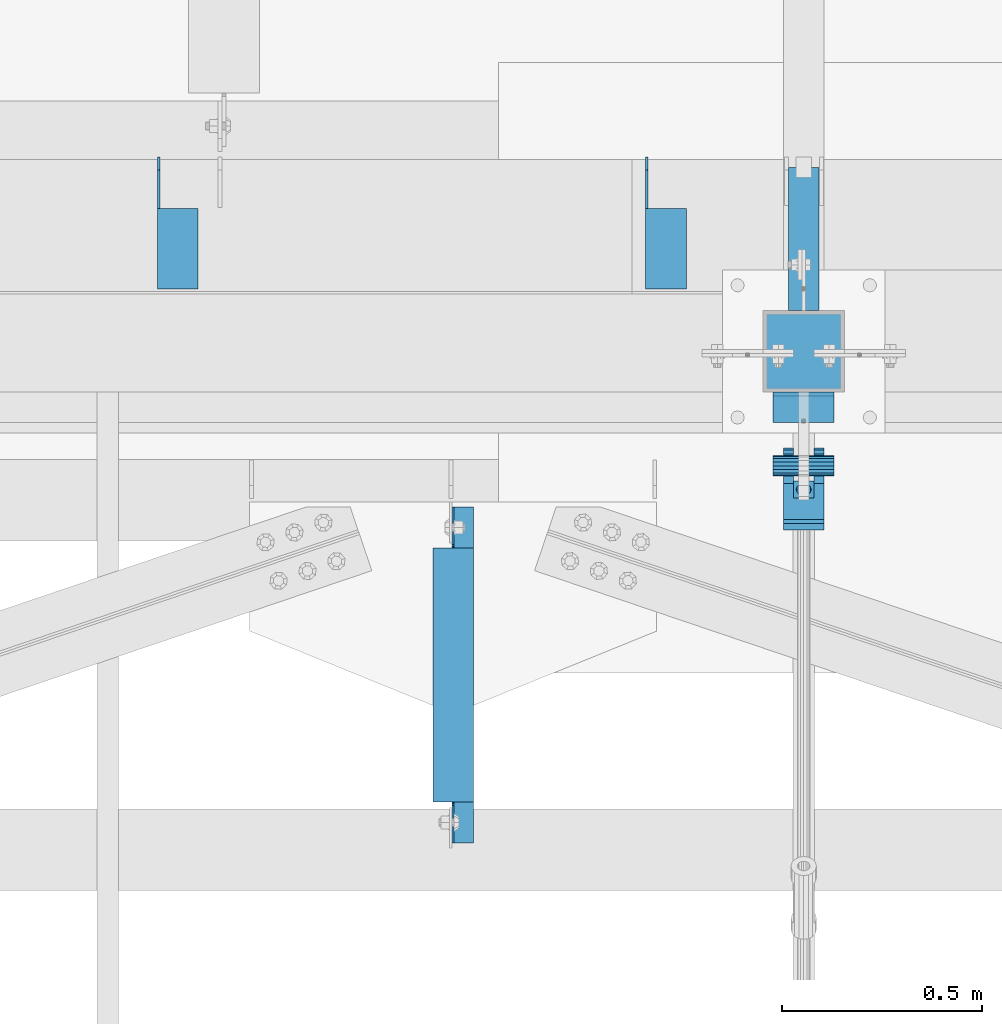
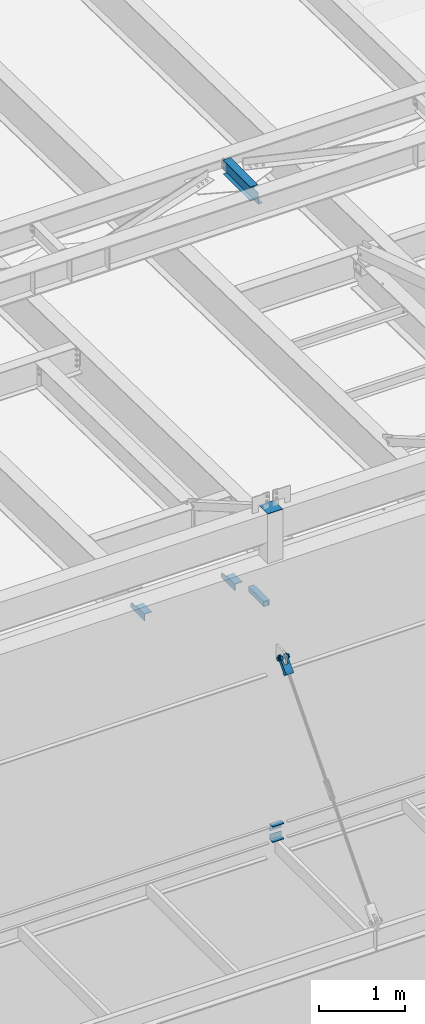
# One storey, part 1206 of 1763: 8 beams, 1 member, 6 elements without a shape of their own.
"""IFC2X3 building model written with IfcOpenShell, lengths in millimetres."""

from ifc_helpers import new_model, si_unit, frame, origin_with_axes, place, context, subcontext, project, spatial, faceted_brep, material, type_object, element, aggregate, save


model = new_model("IFC2X3")

# Units and contexts
model_context = context("Model", 3, precision=1e-05, world=origin_with_axes())
body_context = subcontext(model_context, "Body", "Model", "MODEL_VIEW")
ifc_project = project(units=[si_unit("LENGTHUNIT", "METRE", prefix="MILLI"), si_unit("AREAUNIT", "SQUARE_METRE"), si_unit("VOLUMEUNIT", "CUBIC_METRE"), si_unit("MASSUNIT", "GRAM", prefix="KILO"), si_unit("TIMEUNIT", "SECOND"), si_unit("PLANEANGLEUNIT", "RADIAN"), si_unit("SOLIDANGLEUNIT", "STERADIAN"), si_unit("THERMODYNAMICTEMPERATUREUNIT", "DEGREE_CELSIUS"), si_unit("LUMINOUSINTENSITYUNIT", "LUMEN")], contexts=[model_context])

# Site, building, storey
site_placement = place(None, origin_with_axes())
site = spatial("IfcSite", under=ifc_project, at=site_placement, CompositionType="ELEMENT")
building_placement = place(site_placement, origin_with_axes())
building = spatial("IfcBuilding", under=site, at=building_placement, Name="Undefined", CompositionType="ELEMENT")
storey_placement = place(building_placement, origin_with_axes())
storey = spatial("IfcBuildingStorey", under=building, at=storey_placement, Name="Undefined", CompositionType="ELEMENT", Elevation=0.0)

# Assembly, beams
assembly_1_placement = place(storey_placement, origin_with_axes())
assembly_1 = element("IfcElementAssembly", 1, at=assembly_1_placement, inside=storey, Name="BEAM", AssemblyPlace="NOTDEFINED", PredefinedType="RIGID_FRAME")
ifc_material_1 = material(Name="STEEL/A36")
beam_type_1 = type_object("IfcBeamType", Name="L4X4X1/4", PredefinedType="NOTDEFINED")
beam_1_placement = place(assembly_1_placement, frame((-52362.4055562795, -13723.1435701431, 12153.9), z_axis=(0.0, 0.0, -1.0), x_axis=(0.0, -1.0, 0.0)))
beam_1 = element("IfcBeam", 2, at=beam_1_placement, type_object=beam_type_1, material=ifc_material_1, Name="BRACE", ObjectType="L4X4X1/4", context=body_context, shape_type="Brep", body=[
    faceted_brep([(127.793748474227, 44.4499999999971, -31.7500007627295), (127.793748474227, 50.8000000000029, -31.7500007627295), (127.793748474225, 50.8000000000029, -50.7999999999993), (127.793748474225, -50.8000000000029, -50.7999999999993), (127.793748474225, -50.8000000000029, -44.4500000000007), (127.793748474225, 44.4499999999971, -44.4500000000007), (31.7499999999673, 44.4499999999971, -31.7500001906901), (31.7499999999673, 50.8000000000029, -31.7500007627295), (-1.81898940354586e-10, 44.4500000000371, 50.7999999999374), (-1.96450855582952e-10, 50.8000000000393, 50.7999999999374), (0.0, 50.8000000000029, -1.90690116141923e-07), (0.0, 44.4499999999971, -1.90690116141923e-07), (329.406260681253, 44.4499999999971, 50.7999999999993), (329.406260681253, 50.8000000000029, 50.7999999999993), (329.406260681253, 44.4499999999971, -44.4500000000007), (329.406260681253, -50.8000000000029, -44.4500000000007), (329.406260681253, -50.8000000000029, -50.7999999999993), (329.406260681253, 50.8000000000029, -50.7999999999993)], [[[0, 1, 2, 3, 4, 5]], [[1, 0, 6, 7]], [[8, 9, 10, 11]], [[9, 8, 12, 13]], [[12, 14, 15, 16, 17, 13]], [[15, 14, 5, 4]], [[16, 15, 4, 3]], [[17, 16, 3, 2]], [[9, 13, 17, 2, 1, 7, 10]], [[6, 11, 10, 7]], [[0, 5, 14, 12, 8, 11, 6]]]),
])
beam_2_placement = place(assembly_1_placement, frame((-53581.6055562795, -13723.1435701432, 12153.9), z_axis=(0.0, 0.0, -1.0), x_axis=(0.0, -1.0, 0.0)))
beam_2 = element("IfcBeam", 3, at=beam_2_placement, type_object=beam_type_1, material=ifc_material_1, Name="BRACE", ObjectType="L4X4X1/4", context=body_context, shape_type="Brep", body=[
    faceted_brep([(127.793748474227, 44.4499999999971, -31.7500007627295), (127.793748474227, 50.8000000000029, -31.7500007627295), (127.793748474225, 50.8000000000029, -50.7999999999993), (127.793748474225, -50.8000000000029, -50.7999999999993), (127.793748474225, -50.8000000000029, -44.4500000000007), (127.793748474225, 44.4499999999971, -44.4500000000007), (31.7499999999673, 44.4499999999971, -31.7500001906901), (31.7499999999673, 50.8000000000029, -31.7500007627295), (-1.81898940354586e-10, 44.4500000000371, 50.7999999999374), (-1.96450855582952e-10, 50.8000000000393, 50.7999999999374), (0.0, 50.8000000000029, -1.90690116141923e-07), (0.0, 44.4499999999971, -1.90690116141923e-07), (329.406260681253, 44.4499999999971, 50.7999999999993), (329.406260681253, 50.8000000000029, 50.7999999999993), (329.406260681253, 44.4499999999971, -44.4500000000007), (329.406260681253, -50.8000000000029, -44.4500000000007), (329.406260681253, -50.8000000000029, -50.7999999999993), (329.406260681253, 50.8000000000029, -50.7999999999993)], [[[0, 1, 2, 3, 4, 5]], [[1, 0, 6, 7]], [[8, 9, 10, 11]], [[9, 8, 12, 13]], [[12, 14, 15, 16, 17, 13]], [[15, 14, 5, 4]], [[16, 15, 4, 3]], [[17, 16, 3, 2]], [[9, 13, 17, 2, 1, 7, 10]], [[6, 11, 10, 7]], [[0, 5, 14, 12, 8, 11, 6]]]),
])
aggregate(assembly_1, [beam_1, beam_2])

# Assembly, beam
assembly_2_placement = place(storey_placement, origin_with_axes())
assembly_2 = element("IfcElementAssembly", 4, at=assembly_2_placement, inside=storey, Name="BEAM", AssemblyPlace="NOTDEFINED", PredefinedType="RIGID_FRAME")
ifc_material_2 = material()
beam_type_2 = type_object("IfcBeamType", Name="HSS3X3X1/4", PredefinedType="NOTDEFINED")
beam_3_placement = place(assembly_2_placement, frame((-52018.627008321, -14106.5276214906, 11825.2875), z_axis=(0.0, 0.0, 1.0), x_axis=(0.0, 1.0, 0.0)))
beam_3 = element("IfcBeam", 5, at=beam_3_placement, type_object=beam_type_2, material=ifc_material_2, Name="BEAM", ObjectType="HSS3X3X1/4", context=body_context, shape_type="Brep", body=[
    faceted_brep([(0.0, 31.75, -31.75), (0.0, -31.75, -31.75), (357.9840528735, -31.75, -31.75), (357.9840528735, 31.75, -31.75), (0.0, -31.75, 31.75), (357.9840528735, -31.75, 31.75), (0.0, 31.75, 31.75), (357.9840528735, 31.75, 31.75), (0.0, 38.0999999999985, -38.1000000000004), (0.0, 38.0999999999985, 38.1000000000004), (357.9840528735, 38.0999999999985, 38.1000000000004), (357.9840528735, 38.0999999999985, -38.1000000000004), (0.0, -38.0999999999985, 38.1000000000004), (357.9840528735, -38.0999999999985, 38.1000000000004), (0.0, -38.0999999999985, -38.1000000000004), (357.9840528735, -38.0999999999985, -38.1000000000004)], [[[0, 1, 2, 3]], [[1, 4, 5, 2]], [[4, 6, 7, 5]], [[6, 0, 3, 7]], [[8, 9, 10, 11]], [[9, 12, 13, 10]], [[12, 14, 15, 13]], [[14, 8, 11, 15]], [[13, 15, 11, 10], [5, 7, 3, 2]], [[14, 12, 9, 8], [6, 4, 1, 0]]]),
])
aggregate(assembly_2, [beam_3])

assembly_3_placement = place(storey_placement, origin_with_axes())
assembly_3 = element("IfcElementAssembly", 6, at=assembly_3_placement, inside=storey, Name="BEAM", AssemblyPlace="NOTDEFINED", PredefinedType="RIGID_FRAME")
ifc_material_3 = material(Name="STEEL/A992")
beam_type_3 = type_object("IfcBeamType", Name="W8X10", PredefinedType="NOTDEFINED")
beam_4_placement = place(assembly_3_placement, frame((-52893.869131718, -15452.7273151462, 18721.3875), z_axis=(0.0, 0.0, 1.0), x_axis=(0.0, 1.0, 0.0)))
beam_4 = element("IfcBeam", 7, at=beam_4_placement, type_object=beam_type_3, material=ifc_material_3, Name="BEAM", ObjectType="W8X10", context=body_context, shape_type="Brep", body=[
    faceted_brep([(754.06250467346, 2.68138277246908, -95.25), (754.06250467369, 2.68111138139648, -100.012500000001), (754.062463102084, 50.7999999976746, -100.012500000001), (754.062463102084, 50.7999999976746, -95.25), (855.662552488204, 2.68146872577199, -95.25), (855.662521812792, 2.6811990331189, -100.012500000001), (754.062550374047, 50.7999999976746, 95.25), (754.062583734623, 2.38124999781576, 95.25), (119.062582114304, 2.38124999965657, 95.25), (119.062548753725, 50.7999999995227, 95.25), (119.062552665697, -50.8000000003085, 100.012500000001), (119.062548753725, 50.7999999995227, 100.012500000001), (119.062582114406, 2.38124999965657, 74.3525014877341), (119.062585395783, -2.38125000033324, 74.3525014877341), (119.062585395672, -2.38125000033324, 95.25), (119.062552665697, -50.8000000003085, 95.25), (118.095852191816, 2.38124999965657, 69.4924219696877), (118.095855473193, -2.38125000033324, 69.4924219696877), (115.342838291333, 2.38124999966385, 65.3722455015341), (115.342841572712, -2.38125000031869, 65.3722455015341), (111.222661823174, 2.38124999968568, 62.6192316010565), (111.222665104551, -2.38125000031141, 62.6192316010565), (106.362582305122, 2.38124999969295, 61.652501678469), (106.362585586499, -2.38125000029686, 61.652501678469), (17.4625525194206, 2.38124999996217, 61.652501678469), (17.4625530147059, -2.3812500000422, 61.652501678469), (119.062558086149, 50.7999999995154, -95.25), (119.062558086149, 50.7999999995154, -100.012500000001), (119.062651888697, 2.68138385671773, -100.012500000001), (119.062651889202, 2.68111246564513, -95.25), (17.462499936948, 2.68119506251242, -100.012500000001), (17.462552488254, 2.68092308348423, -95.25), (17.4625580501142, -50.8000000000393, -100.012500000001), (17.4625580501142, -50.8000000000393, -95.25), (17.4625530147059, -2.3812500000422, -95.25), (17.4625525194206, 2.38124999996217, -95.25), (855.662558050122, -50.8000000022803, -100.012500000001), (855.662558050122, -50.8000000022803, -95.25), (855.662553014712, -2.3812500022832, -95.25), (855.662553014712, -2.3812500022832, 61.652501678469), (766.762586825173, -2.38125000221044, 61.652501678469), (761.902507307121, -2.38125000219588, 62.6192316010565), (757.78233083896, -2.38125000218133, 65.3722455015341), (755.02931693848, -2.38125000217406, 69.4924219696877), (754.062587015891, -2.38125000216678, 74.3525014877341), (754.062587015991, -2.38125000216678, 95.25), (754.062552665271, -50.8000000020038, 95.25), (754.062552665271, -50.8000000020038, 100.012500000001), (754.062550374047, 50.7999999976746, 100.012500000001), (754.062583734514, 2.38124999781576, 74.3525014877341), (755.029313657102, 2.38124999781576, 69.4924219696877), (757.782327557585, 2.38124999780848, 65.3722455015341), (761.902504025744, 2.38124999779393, 62.6192316010565), (766.762583543798, 2.38124999777938, 61.652501678469), (855.662552519427, 2.38124999772117, 61.652501678469), (855.662552519427, 2.38124999772117, -95.25)], [[[0, 1, 2, 3]], [[4, 5, 1, 0]], [[6, 7, 8, 9]], [[10, 11, 9, 8, 12, 13, 14, 15]], [[13, 12, 16, 17]], [[17, 16, 18, 19]], [[19, 18, 20, 21]], [[21, 20, 22, 23]], [[23, 22, 24, 25]], [[26, 27, 28, 29]], [[29, 28, 30, 31]], [[32, 33, 34, 25, 24, 35, 31, 30]], [[33, 32, 36, 37]], [[34, 33, 37, 38]], [[17, 19, 21, 23, 25, 34, 38, 39, 40, 41, 42, 43, 44, 45, 14, 13]], [[45, 46, 15, 14]], [[46, 47, 10, 15]], [[47, 48, 11, 10]], [[48, 6, 9, 11]], [[47, 46, 45, 44, 49, 7, 6, 48]], [[43, 50, 49, 44]], [[42, 51, 50, 43]], [[41, 52, 51, 42]], [[40, 53, 52, 41]], [[39, 54, 53, 40]], [[7, 49, 50, 51, 52, 53, 54, 55, 35, 24, 22, 20, 18, 16, 12, 8]], [[35, 55, 4, 0, 3, 26, 29, 31]], [[3, 2, 27, 26]], [[2, 1, 5, 36, 32, 30, 28, 27]], [[55, 54, 39, 38, 37, 36, 5, 4]]]),
])
aggregate(assembly_3, [beam_4])

# Assembly, beams
assembly_4_placement = place(storey_placement, origin_with_axes())
assembly_4 = element("IfcElementAssembly", 8, at=assembly_4_placement, inside=storey, Name="COLUMN", AssemblyPlace="NOTDEFINED", PredefinedType="RIGID_FRAME")
beam_type_4 = type_object("IfcBeamType", Name="L3X3X3/8", PredefinedType="NOTDEFINED")
beam_5_placement = place(assembly_4_placement, frame((-51942.4270144668, -14347.8276133452, 8648.70000000001), z_axis=(0.0, -1.0, 0.0), x_axis=(-1.0, 0.0, 0.0)))
beam_5 = element("IfcBeam", 9, at=beam_5_placement, type_object=beam_type_4, material=ifc_material_1, Name="ANGLE", ObjectType="L3X3X3/8", context=body_context, shape_type="Brep", body=[
    faceted_brep([(0.0, 38.0999999999985, -38.1000000000004), (0.0, 38.0999999999985, 38.1000000000004), (152.400006103515, 38.0999999999985, 38.1000000000058), (152.400006103515, 38.0999999999985, -38.1000000000058), (1.45519152283669e-11, 28.5750000000007, 38.1000000000022), (152.400000000023, 28.5750000000007, 38.0999999999622), (0.0, 28.5750000000007, -28.5750000000007), (152.400000000009, 28.5750000000007, -28.5750000000389), (0.0, -38.1000000000004, -28.5750000000007), (152.400000000009, -38.1000000000004, -28.5750000000389), (0.0, -38.0999999999985, -38.1000000000004), (152.400006103515, -38.0999999999985, -38.1000000000058)], [[[0, 1, 2, 3]], [[1, 4, 5, 2]], [[4, 6, 7, 5]], [[6, 8, 9, 7]], [[8, 10, 11, 9]], [[10, 0, 3, 11]], [[5, 7, 9, 11, 3, 2]], [[10, 8, 6, 4, 1, 0]]]),
])
beam_type_5 = type_object("IfcBeamType", Name="L4X3X3/8", PredefinedType="NOTDEFINED")
beam_6_placement = place(assembly_4_placement, frame((-51942.4270116497, -14347.8276050965, 8788.4), z_axis=(0.0, 0.0, -1.0), x_axis=(-1.0, 0.0, 0.0)))
beam_6 = element("IfcBeam", 10, at=beam_6_placement, type_object=beam_type_5, material=ifc_material_1, Name="ANGLE", ObjectType="L4X3X3/8", context=body_context, shape_type="Brep", body=[
    faceted_brep([(1.45519152283669e-10, 38.0999999999985, -50.7999999999993), (1.45519152283669e-10, 38.0999999999985, 50.7999999999993), (152.400000000147, 38.1000000000186, 50.7999999999993), (152.400000000147, 38.1000000000186, -50.7999999999993), (1.09139364212751e-10, 28.5749999999989, 50.7999999999993), (152.400000000111, 28.5750000000171, 50.7999999999993), (1.09139364212751e-10, 28.5749999999989, -41.2749999999996), (152.400000000111, 28.5750000000171, -41.2749999999996), (-1.23691279441118e-10, -38.1000000000022, -41.2749999999996), (152.399999999878, -38.0999999999822, -41.2749999999996), (-1.23691279441118e-10, -38.1000000000022, -50.7999999999993), (152.399999999878, -38.0999999999822, -50.7999999999993)], [[[0, 1, 2, 3]], [[1, 4, 5, 2]], [[4, 6, 7, 5]], [[6, 8, 9, 7]], [[8, 10, 11, 9]], [[10, 0, 3, 11]], [[5, 7, 9, 11, 3, 2]], [[10, 8, 6, 4, 1, 0]]]),
])

# Assembly, beam
assembly_5_placement = place(storey_placement, origin_with_axes())
assembly_5 = element("IfcElementAssembly", 11, at=assembly_5_placement, inside=storey, Name="PIN", AssemblyPlace="NOTDEFINED", PredefinedType="RIGID_FRAME")
beam_type_6 = type_object("IfcBeamType", PredefinedType="NOTDEFINED")
beam_7_placement = place(assembly_5_placement, frame((-52094.827008321, -14493.8776228191, 11290.3000019096), z_axis=(0.0, 0.0, 1.0), x_axis=(1.0, 0.0, 0.0)))
beam_7 = element("IfcBeam", 12, at=beam_7_placement, type_object=beam_type_6, material=ifc_material_2, Name="PIN", context=body_context, shape_type="Brep", body=[
    faceted_brep([(0.0, -25.4000000000015, 0.0), (0.0, -23.466540125788, -9.72015918207308), (152.400103102711, -23.466540125788, -9.72015918207308), (152.400103102711, -25.4000000000015, 0.0), (0.0, -17.9605122421381, -17.9605122421385), (152.400103102711, -17.9605122421381, -17.9605122421385), (0.0, -9.72015918207398, -23.4665401257867), (152.400103102711, -9.72015918207398, -23.4665401257867), (0.0, 0.0, -25.4000000000001), (152.400103102711, 0.0, -25.4000000000001), (0.0, 9.72015918207398, -23.4665401257867), (152.400103102711, 9.72015918207398, -23.4665401257867), (0.0, 17.9605122421381, -17.9605122421385), (152.400103102711, 17.9605122421381, -17.9605122421385), (0.0, 23.466540125788, -9.72015918207308), (152.400103102711, 23.466540125788, -9.72015918207308), (0.0, 25.4000000000015, 0.0), (152.400103102711, 25.4000000000015, 0.0), (0.0, 23.466540125788, 9.72015918207308), (152.400103102711, 23.466540125788, 9.72015918207308), (0.0, 17.9605122421381, 17.9605122421385), (152.400103102711, 17.9605122421381, 17.9605122421385), (0.0, 9.72015918207398, 23.4665401257867), (152.400103102711, 9.72015918207398, 23.4665401257867), (0.0, 0.0, 25.4000000000001), (152.400103102711, 0.0, 25.4000000000001), (0.0, -9.72015918207398, 23.4665401257867), (152.400103102711, -9.72015918207398, 23.4665401257867), (0.0, -17.9605122421381, 17.9605122421385), (152.400103102711, -17.9605122421381, 17.9605122421385), (0.0, -23.466540125788, 9.72015918207308), (152.400103102711, -23.466540125788, 9.72015918207308)], [[[0, 1, 2, 3]], [[1, 4, 5, 2]], [[4, 6, 7, 5]], [[6, 8, 9, 7]], [[8, 10, 11, 9]], [[10, 12, 13, 11]], [[12, 14, 15, 13]], [[14, 16, 17, 15]], [[16, 18, 19, 17]], [[18, 20, 21, 19]], [[20, 22, 23, 21]], [[22, 24, 25, 23]], [[24, 26, 27, 25]], [[26, 28, 29, 27]], [[28, 30, 31, 29]], [[30, 0, 3, 31]], [[5, 7, 9, 11, 13, 15, 17, 19, 21, 23, 25, 27, 29, 31, 3, 2]], [[30, 28, 26, 24, 22, 20, 18, 16, 14, 12, 10, 8, 6, 4, 1, 0]]]),
])
aggregate(assembly_5, [beam_7])

# Assembly, member
assembly_6_placement = place(storey_placement, origin_with_axes())
assembly_6 = element("IfcElementAssembly", 13, at=assembly_6_placement, inside=storey, Name="HANGER ROD", AssemblyPlace="NOTDEFINED", PredefinedType="RIGID_FRAME")
member_type = type_object("IfcMemberType", PredefinedType="NOTDEFINED")
member_placement = place(assembly_6_placement, frame((-52018.627008321, -14464.5701432834, 11323.7196689226), z_axis=(-1.0, 0.0, 0.0), x_axis=(0.0, -0.659331697240892, -0.751852188274693)))
member = element("IfcMember", 14, at=member_placement, type_object=member_type, material=ifc_material_1, context=body_context, shape_type="Brep", body=[
    faceted_brep([(254.000002114522, 9.52500000169675, 16.4977839419953), (134.273330688089, 9.52500000160944, 16.4977839419953), (134.273330688083, 16.4977839436942, 9.52499999989959), (254.000002182145, 16.4977839437852, 9.52499999989959), (134.273330688081, 19.0500000015963, -1.01863406598568e-10), (254.000002023278, 19.0500000016909, -1.01863406598568e-10), (134.273330688083, 16.4977839436942, -9.52500000010332), (254.000001680489, 16.4977839437852, -9.52500000010332), (134.273330688089, 9.52500000160944, -16.497783942199), (254.000001245629, 9.52500000169675, -16.497783942199), (134.273330688098, 1.61890056915581e-09, -19.0500000001048), (254.000000835218, 1.70985003933311e-09, -19.0500000001048), (134.273330688103, -9.52499999837164, -16.497783942199), (254.000000559224, -9.52499999827705, -16.497783942199), (134.273330688109, -16.4977839404564, -9.52500000010332), (254.000000491603, -16.4977839403655, -9.52500000010332), (134.273330688112, -19.0499999983585, -1.01863406598568e-10), (254.000000650468, -19.0499999982676, -1.01863406598568e-10), (134.273330688109, -16.4977839404564, 9.52499999989959), (254.000000993259, -16.4977839403655, 9.52499999989959), (134.273330688103, -9.52499999837164, 16.4977839419953), (254.000001428119, -9.52499999827705, 16.4977839419953), (134.273330688098, 1.61890056915581e-09, 19.049999999901), (254.00000183853, 1.70985003933311e-09, 19.049999999901), (78.4980859522016, 28.5827170717785, -50.8000000000029), (71.5070499125045, 35.2741161661834, -50.8000000000029), (71.5070499125045, 35.2741161661834, -25.3999992370664), (78.4980859522016, 28.5827170717785, -25.3999992370664), (63.2335594920528, 40.2939531168813, -50.8000000000029), (63.2335594920528, 40.2939531168813, -25.3999992370664), (54.0697628847552, 43.4042969063921, -50.8000000000029), (54.0697628847552, 43.4042969063921, -25.3999992370664), (44.4500000032872, 44.4500000000189, -50.8000000000029), (44.4500000032872, 44.4500000003973, -25.3999992370664), (27.4397209215654, 41.0664449477481, -50.8000000000029), (27.4397209215654, 41.0664449477481, -25.3999992370664), (13.0191026972475, 31.4308957019275, -50.8000000000029), (13.0191026972475, 31.4308957019275, -25.3999992370664), (3.38355373177319, 17.0102772902901, -50.8000000000029), (3.38355373177319, 17.0102772902901, -25.3999992370664), (0.0, 0.0, -50.7999992370605), (0.0, 0.0, -25.4000000000001), (3.38355545789955, -17.0102785002382, -50.8000000000029), (3.38355545789955, -17.0102785002382, -25.3999992370664), (13.0191044786457, -31.4308962839314, -50.8000000000029), (13.0191044786457, -31.4308962839314, -25.3999992370664), (27.4397222623497, -41.066445304652, -50.8000000000029), (27.4397222623497, -41.066445304652, -25.3999992370664), (44.4500007625898, -44.4499999999498, -50.8000000000029), (44.4500007625898, -44.4500001906781, -25.3999992370664), (54.0697566383383, -43.3965760809588, -50.8000000000029), (54.0697566383383, -43.3965760809588, -25.3999992370664), (63.2335536920523, -40.2862336066682, -50.8000000000029), (63.2335536920523, -40.2862336066682, -25.3999992370664), (71.507044832973, -35.266397843403, -50.8000000000029), (71.507044832973, -35.266397843403, -25.3999992370664), (78.4980818330437, -28.5749997523744, -50.8000000000029), (78.4980818330437, -28.5749997523744, -25.3999992370664), (71.5070499125045, 35.2741161661834, 50.8000000000029), (78.4980859522016, 28.5827170717785, 50.8000000000029), (78.4980859522016, 28.5827170717785, 25.3999999999942), (71.5070499125045, 35.2741161661834, 25.3999999999942), (63.2335594920528, 40.2939531168813, 50.8000000000029), (63.2335594920528, 40.2939531168813, 25.3999999999942), (54.0697628847552, 43.4042969063921, 50.8000000000029), (54.0697628847552, 43.4042969063921, 25.3999999999942), (44.4500000032872, 44.4500000015396, 50.8000000000029), (44.450000003289, 44.4500000011612, 25.3999999999942), (27.4397209215654, 41.0664449477481, 50.8000000000029), (27.4397209215654, 41.0664449477481, 25.3999999999942), (13.0191026972475, 31.4308957019275, 50.8000000000029), (13.0191026972475, 31.4308957019275, 25.3999999999942), (3.38355373177319, 17.0102772902901, 50.8000000000029), (3.38355373177319, 17.0102772902901, 25.3999999999942), (0.0, 0.0, 50.7999992370605), (0.0, 0.0, 25.4000000000001), (3.38355545789955, -17.0102785002382, 50.8000000000029), (3.38355545789955, -17.0102785002382, 25.3999999999942), (13.0191044786457, -31.4308962839314, 50.8000000000029), (13.0191044786457, -31.4308962839314, 25.3999999999942), (27.4397222623497, -41.066445304652, 50.8000000000029), (27.4397222623497, -41.066445304652, 25.3999999999942), (44.4500007625898, -44.4500007628594, 50.8000000000029), (44.4500007625898, -44.4500005721347, 25.3999999999942), (54.0697566383383, -43.3965760809588, 50.8000000000029), (54.0697566383383, -43.3965760809588, 25.3999999999942), (63.2335536920523, -40.2862336066682, 50.8000000000029), (63.2335536920523, -40.2862336066682, 25.3999999999942), (71.507044832973, -35.266397843403, 50.8000000000029), (71.507044832973, -35.266397843403, 25.3999999999942), (78.4980818330437, -28.5749997523744, 50.8000000000029), (78.4980818330437, -28.5749997523744, 25.3999999999942), (215.900005804647, -28.5749978020685, -50.8000000000029), (215.900005804647, -28.5749978020685, 50.8000000000029), (134.273330688118, -28.574998960692, 25.3999999999942), (134.273330688118, -28.574998960692, -25.3999992370664), (215.899998542161, -41.274998426099, -50.8000000000029), (215.899998542161, -41.274998426099, 50.8000000000029), (254.000000615249, -28.5749978178974, 50.8000000000029), (253.999999999285, -28.5749978178974, -50.8000000000029), (253.999999999241, 28.5826899486601, -50.8000000000029), (254.000004734274, 28.5826899486601, 50.8000000000029), (215.900009923701, 28.5826954010772, 50.8000000000029), (215.900004483963, 41.2826960251004, 50.8000000000029), (65.3837779449618, -23.8713099949055, 50.8000000000029), (54.6551341370573, -30.0652247148719, 50.8000000000029), (42.3728511665136, -31.6819815137387, 50.8000000000029), (30.4067952764267, -28.4754438248128, 50.8000000000029), (20.5786900034959, -20.9337779439011, 50.8000000000029), (14.3847752835277, -10.2051341359947, 50.8000000000029), (12.7680184846608, 2.07714883454901, 50.8000000000029), (15.9745561735849, 14.0432047246359, 50.8000000000029), (23.5162220544985, 23.8713099975648, 50.8000000000029), (34.2448658624066, 30.0652247175349, 50.8000000000029), (46.5271488329486, 31.6819815164017, 50.8000000000029), (58.4932047230354, 28.4754438274795, 50.8000000000029), (68.3213099959662, 20.9337779465641, 50.8000000000029), (74.5152247159344, 10.2051341386577, 50.8000000000029), (76.1319815147995, -2.07714883188601, 50.8000000000029), (72.9254438258772, -14.0432047219729, 50.8000000000029), (65.3837779449618, -23.8713099949055, 25.3999999999942), (54.6551341370573, -30.0652247148719, 25.3999999999942), (42.3728511665136, -31.6819815137387, 25.3999999999942), (30.4067952764267, -28.4754438248128, 25.3999999999942), (20.5786900034959, -20.9337779439011, 25.3999999999942), (14.3847752835277, -10.2051341359947, 25.3999999999942), (12.7680184846608, 2.07714883454901, 25.3999999999942), (15.9745561735849, 14.0432047246359, 25.3999999999942), (23.5162220544985, 23.8713099975648, 25.3999999999942), (34.2448658624066, 30.0652247175349, 25.3999999999942), (46.5271488329486, 31.6819815164017, 25.3999999999942), (58.4932047230354, 28.4754438274795, 25.3999999999942), (68.3213099959662, 20.9337779465641, 25.3999999999942), (74.5152247159344, 10.2051341386577, 25.3999999999942), (76.1319815147995, -2.07714883188601, 25.3999999999942), (72.9254438258772, -14.0432047219729, 25.3999999999942), (134.273330688074, 28.5827082750402, 25.3999999999942), (215.900009923701, 28.5826954010772, -50.8000000000029), (134.273330688074, 28.5827082750402, -25.3999992370664), (215.900004483963, 41.2826960251004, -50.8000000000029), (68.3213099959662, 20.9337779465641, -50.8000000000029), (58.4932047230354, 28.4754438274795, -50.8000000000029), (46.5271488329486, 31.6819815164017, -50.8000000000029), (34.2448658624066, 30.0652247175349, -50.8000000000029), (23.5162220544985, 23.8713099975648, -50.8000000000029), (15.9745561735849, 14.0432047246359, -50.8000000000029), (12.7680184846608, 2.07714883454901, -50.8000000000029), (14.3847752835277, -10.2051341359947, -50.8000000000029), (20.5786900034959, -20.9337779439011, -50.8000000000029), (30.4067952764267, -28.4754438248128, -50.8000000000029), (42.3728511665136, -31.6819815137387, -50.8000000000029), (54.6551341370573, -30.0652247148719, -50.8000000000029), (65.3837779449618, -23.8713099949055, -50.8000000000029), (72.9254438258772, -14.0432047219729, -50.8000000000029), (76.1319815147995, -2.07714883188601, -50.8000000000029), (74.5152247159344, 10.2051341386577, -50.8000000000029), (68.3213099959662, 20.9337779465641, -25.3999992370664), (58.4932047230354, 28.4754438274795, -25.3999992370664), (46.5271488329486, 31.6819815164017, -25.3999992370664), (34.2448658624066, 30.0652247175349, -25.3999992370664), (23.5162220544985, 23.8713099975648, -25.3999992370664), (15.9745561735849, 14.0432047246359, -25.3999992370664), (12.7680184846608, 2.07714883454901, -25.3999992370664), (14.3847752835277, -10.2051341359947, -25.3999992370664), (20.5786900034959, -20.9337779439011, -25.3999992370664), (30.4067952764267, -28.4754438248128, -25.3999992370664), (42.3728511665136, -31.6819815137387, -25.3999992370664), (54.6551341370573, -30.0652247148719, -25.3999992370664), (65.3837779449618, -23.8713099949055, -25.3999992370664), (72.9254438258772, -14.0432047219729, -25.3999992370664), (76.1319815147995, -2.07714883188601, -25.3999992370664), (74.5152247159344, 10.2051341386577, -25.3999992370664)], [[[0, 1, 2, 3]], [[3, 2, 4, 5]], [[5, 4, 6, 7]], [[7, 6, 8, 9]], [[9, 8, 10, 11]], [[11, 10, 12, 13]], [[13, 12, 14, 15]], [[15, 14, 16, 17]], [[17, 16, 18, 19]], [[19, 18, 20, 21]], [[21, 20, 22, 23]], [[23, 22, 1, 0]], [[24, 25, 26, 27]], [[25, 28, 29, 26]], [[28, 30, 31, 29]], [[30, 32, 33, 31]], [[32, 34, 35, 33]], [[34, 36, 37, 35]], [[36, 38, 39, 37]], [[38, 40, 41, 39]], [[40, 42, 43, 41]], [[42, 44, 45, 43]], [[44, 46, 47, 45]], [[46, 48, 49, 47]], [[48, 50, 51, 49]], [[50, 52, 53, 51]], [[52, 54, 55, 53]], [[54, 56, 57, 55]], [[58, 59, 60, 61]], [[62, 58, 61, 63]], [[64, 62, 63, 65]], [[66, 64, 65, 67]], [[68, 66, 67, 69]], [[70, 68, 69, 71]], [[72, 70, 71, 73]], [[74, 72, 73, 75]], [[76, 74, 75, 77]], [[78, 76, 77, 79]], [[80, 78, 79, 81]], [[82, 80, 81, 83]], [[84, 82, 83, 85]], [[86, 84, 85, 87]], [[88, 86, 87, 89]], [[90, 88, 89, 91]], [[57, 56, 92, 93, 90, 91, 94, 95]], [[93, 92, 96, 97]], [[98, 97, 96, 99]], [[98, 99, 100, 101], [3, 5, 7, 9, 11, 13, 15, 17, 19, 21, 23, 0]], [[102, 59, 58, 62, 64, 66, 68, 70, 72, 74, 76, 78, 80, 82, 84, 86, 88, 90, 93, 97, 98, 101, 103], [104, 105, 106, 107, 108, 109, 110, 111, 112, 113, 114, 115, 116, 117, 118, 119]], [[105, 104, 120, 121]], [[106, 105, 121, 122]], [[107, 106, 122, 123]], [[108, 107, 123, 124]], [[109, 108, 124, 125]], [[110, 109, 125, 126]], [[111, 110, 126, 127]], [[112, 111, 127, 128]], [[113, 112, 128, 129]], [[114, 113, 129, 130]], [[115, 114, 130, 131]], [[116, 115, 131, 132]], [[117, 116, 132, 133]], [[118, 117, 133, 134]], [[119, 118, 134, 135]], [[104, 119, 135, 120]], [[91, 89, 87, 85, 83, 81, 79, 77, 75, 73, 71, 69, 67, 65, 63, 61, 60, 136, 94], [134, 133, 132, 131, 130, 129, 128, 127, 126, 125, 124, 123, 122, 121, 120, 135]], [[59, 102, 137, 24, 27, 138, 136, 60]], [[103, 139, 137, 102]], [[101, 100, 139, 103]], [[99, 96, 92, 56, 54, 52, 50, 48, 46, 44, 42, 40, 38, 36, 34, 32, 30, 28, 25, 24, 137, 139, 100], [140, 141, 142, 143, 144, 145, 146, 147, 148, 149, 150, 151, 152, 153, 154, 155]], [[141, 140, 156, 157]], [[142, 141, 157, 158]], [[143, 142, 158, 159]], [[144, 143, 159, 160]], [[145, 144, 160, 161]], [[146, 145, 161, 162]], [[147, 146, 162, 163]], [[148, 147, 163, 164]], [[149, 148, 164, 165]], [[150, 149, 165, 166]], [[151, 150, 166, 167]], [[152, 151, 167, 168]], [[153, 152, 168, 169]], [[154, 153, 169, 170]], [[155, 154, 170, 171]], [[140, 155, 171, 156]], [[95, 138, 27, 26, 29, 31, 33, 35, 37, 39, 41, 43, 45, 47, 49, 51, 53, 55, 57], [170, 169, 168, 167, 166, 165, 164, 163, 162, 161, 160, 159, 158, 157, 156, 171]], [[94, 136, 138, 95], [18, 16, 14, 12, 10, 8, 6, 4, 2, 1, 22, 20]]]),
])
aggregate(assembly_6, [member])

# Beam
beam_type_7 = type_object("IfcBeamType", PredefinedType="NOTDEFINED")
beam_8_placement = place(assembly_4_placement, frame((-52018.627008321, -14309.7275894107, 13255.6250000013), z_axis=(1.0, 0.0, 0.0), x_axis=(0.0, 1.0, 0.0)))
beam_8 = element("IfcBeam", 15, at=beam_8_placement, type_object=beam_type_7, material=ifc_material_1, Name="PLATE", context=body_context, shape_type="Brep", body=[
    faceted_brep([(0.0, 3.1749999995518, -101.600000000005), (0.0, 3.17499999999927, 101.599998474121), (203.200000000001, 3.17500000054133, 101.600000000011), (203.200000000001, 3.1749999995518, -101.600000000005), (0.0, -3.17499999999927, 101.599998474121), (203.200000000001, -3.17499999950815, 101.600000000005), (0.0, -3.17500000051223, -101.600000000012), (203.200000000001, -3.17500000051223, -101.600000000012)], [[[0, 1, 2, 3]], [[1, 4, 5, 2]], [[4, 6, 7, 5]], [[6, 0, 3, 7]], [[5, 7, 3, 2]], [[6, 4, 1, 0]]]),
])

aggregate(assembly_4, [beam_5, beam_6, beam_8])

save(model, "model.ifc")
